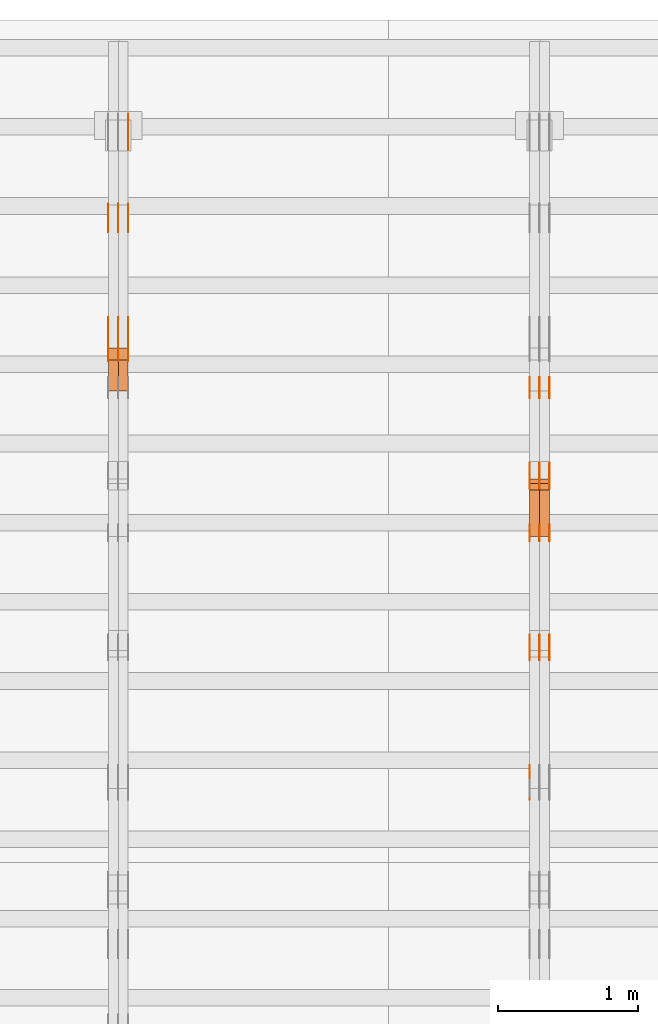
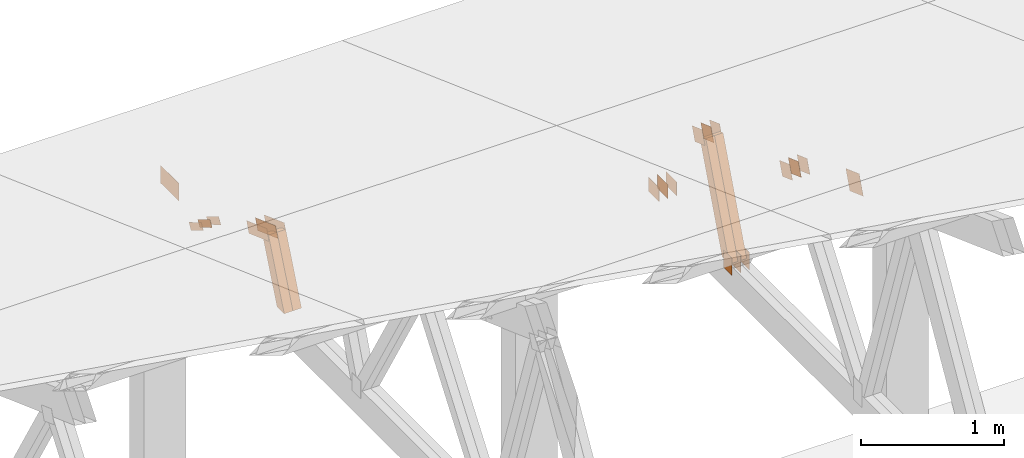
# One storey, part 117 of 189: 30 proxies.
"""IFC2X3 building model written with IfcOpenShell, lengths in millimetres."""

from ifc_helpers import new_model, entity, si_unit, converted_unit, derived_unit, direction, frame, frame_2d, origin, origin_2d_with_axis, place, context, subcontext, project, spatial, polyline, rectangle, outline, extrude, source, transform, mapped, material, type_object, type_shapes, element, save


model = new_model("IFC2X3")

# Units and contexts
model_context = context("Model", 3, precision=0.01, world=origin(), true_north=direction((6.12303176911189e-17, 1.0)))
body_context = subcontext(model_context, "Body", "Model", "MODEL_VIEW")
ifc_project = project(units=[si_unit("LENGTHUNIT", "METRE", prefix="MILLI"), si_unit("AREAUNIT", "SQUARE_METRE"), si_unit("VOLUMEUNIT", "CUBIC_METRE"), converted_unit("PLANEANGLEUNIT", "DEGREE", entity("IfcRatioMeasure", 0.0174532925199433), si_unit("PLANEANGLEUNIT", "RADIAN"), dimensions=[0, 0, 0, 0, 0, 0, 0]), si_unit("MASSUNIT", "GRAM", prefix="KILO"), derived_unit("MASSDENSITYUNIT", [(si_unit("MASSUNIT", "GRAM", prefix="KILO"), 1), (si_unit("LENGTHUNIT", "METRE"), -3)]), si_unit("TIMEUNIT", "SECOND"), si_unit("FREQUENCYUNIT", "HERTZ"), si_unit("THERMODYNAMICTEMPERATUREUNIT", "DEGREE_CELSIUS"), derived_unit("THERMALTRANSMITTANCEUNIT", [(si_unit("MASSUNIT", "GRAM", prefix="KILO"), 1), (si_unit("THERMODYNAMICTEMPERATUREUNIT", "KELVIN"), -1), (si_unit("TIMEUNIT", "SECOND"), -3)]), derived_unit("VOLUMETRICFLOWRATEUNIT", [(si_unit("LENGTHUNIT", "METRE"), 3), (si_unit("TIMEUNIT", "SECOND"), -1)]), si_unit("ELECTRICCURRENTUNIT", "AMPERE"), si_unit("ELECTRICVOLTAGEUNIT", "VOLT"), si_unit("POWERUNIT", "WATT"), si_unit("FORCEUNIT", "NEWTON"), si_unit("ILLUMINANCEUNIT", "LUX"), si_unit("LUMINOUSFLUXUNIT", "LUMEN"), si_unit("LUMINOUSINTENSITYUNIT", "CANDELA"), derived_unit("USERDEFINED", [(si_unit("MASSUNIT", "GRAM", prefix="KILO"), -1), (si_unit("LENGTHUNIT", "METRE"), -2), (si_unit("TIMEUNIT", "SECOND"), 3), (si_unit("LUMINOUSFLUXUNIT", "LUMEN"), 1)]), derived_unit("LINEARVELOCITYUNIT", [(si_unit("LENGTHUNIT", "METRE"), 1), (si_unit("TIMEUNIT", "SECOND"), -1)]), si_unit("PRESSUREUNIT", "PASCAL"), derived_unit("USERDEFINED", [(si_unit("LENGTHUNIT", "METRE"), -2), (si_unit("MASSUNIT", "GRAM", prefix="KILO"), 1), (si_unit("TIMEUNIT", "SECOND"), -2)])], contexts=[model_context])

# Site, building, storey
site_placement = place(None, origin())
site = spatial("IfcSite", under=ifc_project, at=site_placement, CompositionType="ELEMENT")
building_placement = place(site_placement, origin())
building = spatial("IfcBuilding", under=site, at=building_placement, CompositionType="ELEMENT")
storey_placement = place(building_placement, origin())
storey = spatial("IfcBuildingStorey", under=building, at=storey_placement, Name="Default", CompositionType="ELEMENT", Elevation=0.0)

# Proxies
ifc_material_1 = material(Name="IfcSurfaceStyle #73986")
building_element_proxy_type_1 = type_object("IfcBuildingElementProxyType", PredefinedType="NOTDEFINED", material=ifc_material_1)
shared_shape_1 = source(origin(), body_context, "Body", "SweptSolid", [
    extrude(outline(polyline([(-74.9999475298494, -60.0), (75.0000042257432, -60.0), (74.9999684051025, 60.0), (-75.0000251009963, 60.0), (-74.9999475298494, -60.0)])), frame((75.0000607644577, 60.0000865490217, 0.0), z_axis=(0.0, 0.0, 1.0), x_axis=(-1.0, 0.0, 0.0)), (0.0, 0.0, 1.0), 1.3),
])
type_shapes(building_element_proxy_type_1, [shared_shape_1])
proxy_1_placement = place(building_placement, frame((12301.3, 25732.0586805394, 1446.84420669249), z_axis=(-1.0, 0.0, 0.0), x_axis=(0.0, -0.939692620785908, 0.342020143325669)))
element("IfcBuildingElementProxy", 1, at=proxy_1_placement, inside=storey, type_object=building_element_proxy_type_1, material=ifc_material_1, context=body_context, shape_type="MappedRepresentation", body=[
    mapped(shared_shape_1, transform((0.0, 0.0, 0.0), scale=1.0)),
])
ifc_material_2 = material(Name="IfcSurfaceStyle #73929")
building_element_proxy_type_2 = type_object("IfcBuildingElementProxyType", PredefinedType="NOTDEFINED", material=ifc_material_2)
shared_shape_2 = source(origin(), body_context, "Body", "SweptSolid", [
    extrude(outline(polyline([(-74.9999475298494, -60.0), (75.0000042257432, -60.0), (74.9999684051025, 60.0), (-75.0000251009963, 60.0), (-74.9999475298494, -60.0)])), frame((75.0000607644577, 60.0000865490217, 0.0), z_axis=(0.0, 0.0, 1.0), x_axis=(-1.0, 0.0, 0.0)), (0.0, 0.0, 1.0), 1.29999999999999),
])
type_shapes(building_element_proxy_type_2, [shared_shape_2])
proxy_2_placement = place(building_placement, frame((12230.0, 25732.0586805394, 1446.84420669249), z_axis=(-1.0, 0.0, 0.0), x_axis=(0.0, -0.939692620785908, 0.342020143325669)))
element("IfcBuildingElementProxy", 2, at=proxy_2_placement, inside=storey, type_object=building_element_proxy_type_2, material=ifc_material_2, context=body_context, shape_type="MappedRepresentation", body=[
    mapped(shared_shape_2, transform((0.0, 0.0, 0.0), scale=1.0)),
])
ifc_material_3 = material(Name="IfcSurfaceStyle #73872")
building_element_proxy_type_3 = type_object("IfcBuildingElementProxyType", PredefinedType="NOTDEFINED", material=ifc_material_3)
shared_shape_3 = source(origin(), body_context, "Body", "SweptSolid", [
    extrude(outline(polyline([(-74.9999475298494, -60.0), (75.0000042257432, -60.0), (74.9999684051025, 60.0), (-75.0000251009963, 60.0), (-74.9999475298494, -60.0)])), frame((75.0000607644577, 60.0000865490217, 0.0), z_axis=(0.0, 0.0, 1.0), x_axis=(-1.0, 0.0, 0.0)), (0.0, 0.0, 1.0), 1.29999999999999),
])
type_shapes(building_element_proxy_type_3, [shared_shape_3])
proxy_3_placement = place(building_placement, frame((12231.3, 25732.0586805394, 1446.84420669249), z_axis=(-1.0, 0.0, 0.0), x_axis=(0.0, -0.939692620785908, 0.342020143325669)))
element("IfcBuildingElementProxy", 3, at=proxy_3_placement, inside=storey, type_object=building_element_proxy_type_3, material=ifc_material_3, context=body_context, shape_type="MappedRepresentation", body=[
    mapped(shared_shape_3, transform((0.0, 0.0, 0.0), scale=1.0)),
])
ifc_material_4 = material(Name="IfcSurfaceStyle #73815")
building_element_proxy_type_4 = type_object("IfcBuildingElementProxyType", PredefinedType="NOTDEFINED", material=ifc_material_4)
shared_shape_4 = source(origin(), body_context, "Body", "SweptSolid", [
    extrude(outline(polyline([(-74.9999475298494, -60.0), (75.0000042257432, -60.0), (74.9999684051025, 60.0), (-75.0000251009963, 60.0), (-74.9999475298494, -60.0)])), frame((75.0000607644577, 60.0000865490217, 0.0), z_axis=(0.0, 0.0, 1.0), x_axis=(-1.0, 0.0, 0.0)), (0.0, 0.0, 1.0), 1.29999999999999),
])
type_shapes(building_element_proxy_type_4, [shared_shape_4])
proxy_4_placement = place(building_placement, frame((12160.0, 25732.0586805394, 1446.84420669249), z_axis=(-1.0, 0.0, 0.0), x_axis=(0.0, -0.939692620785908, 0.342020143325669)))
element("IfcBuildingElementProxy", 4, at=proxy_4_placement, inside=storey, type_object=building_element_proxy_type_4, material=ifc_material_4, context=body_context, shape_type="MappedRepresentation", body=[
    mapped(shared_shape_4, transform((0.0, 0.0, 0.0), scale=1.0)),
])
ifc_material_5 = material(Name="IfcSurfaceStyle #73758")
building_element_proxy_type_5 = type_object("IfcBuildingElementProxyType", PredefinedType="NOTDEFINED", material=ifc_material_5)
shared_shape_5 = source(origin(), body_context, "Body", "SweptSolid", [
    extrude(rectangle(XDim=150.0, YDim=120.0, at=frame_2d((-7.105427357601e-15, 0.0), x_axis=(1.0, 0.0))), frame((75.0, 60.0, 0.0), z_axis=(0.0, 0.0, 1.0), x_axis=(-1.0, 0.0, 0.0)), (0.0, 0.0, 1.0), 1.3),
])
type_shapes(building_element_proxy_type_5, [shared_shape_5])
proxy_5_placement = place(building_placement, frame((12301.3, 26439.0083007813, 170.0), z_axis=(-1.0, 0.0, 0.0), x_axis=(0.0, 0.0, 1.0)))
element("IfcBuildingElementProxy", 5, at=proxy_5_placement, inside=storey, type_object=building_element_proxy_type_5, material=ifc_material_5, context=body_context, shape_type="MappedRepresentation", body=[
    mapped(shared_shape_5, transform((0.0, 0.0, 0.0), scale=1.0)),
])
ifc_material_6 = material(Name="IfcSurfaceStyle #73701")
building_element_proxy_type_6 = type_object("IfcBuildingElementProxyType", PredefinedType="NOTDEFINED", material=ifc_material_6)
shared_shape_6 = source(origin(), body_context, "Body", "SweptSolid", [
    extrude(rectangle(XDim=150.0, YDim=120.0, at=frame_2d((-7.105427357601e-15, 0.0), x_axis=(1.0, 0.0))), frame((75.0, 60.0, 0.0), z_axis=(0.0, 0.0, 1.0), x_axis=(-1.0, 0.0, 0.0)), (0.0, 0.0, 1.0), 1.29999999999999),
])
type_shapes(building_element_proxy_type_6, [shared_shape_6])
proxy_6_placement = place(building_placement, frame((12230.0, 26439.0083007813, 170.0), z_axis=(-1.0, 0.0, 0.0), x_axis=(0.0, 0.0, 1.0)))
element("IfcBuildingElementProxy", 6, at=proxy_6_placement, inside=storey, type_object=building_element_proxy_type_6, material=ifc_material_6, context=body_context, shape_type="MappedRepresentation", body=[
    mapped(shared_shape_6, transform((0.0, 0.0, 0.0), scale=1.0)),
])
ifc_material_7 = material(Name="IfcSurfaceStyle #73644")
building_element_proxy_type_7 = type_object("IfcBuildingElementProxyType", PredefinedType="NOTDEFINED", material=ifc_material_7)
shared_shape_7 = source(origin(), body_context, "Body", "SweptSolid", [
    extrude(rectangle(XDim=150.0, YDim=120.0, at=frame_2d((-7.105427357601e-15, 0.0), x_axis=(1.0, 0.0))), frame((75.0, 60.0, 0.0), z_axis=(0.0, 0.0, 1.0), x_axis=(-1.0, 0.0, 0.0)), (0.0, 0.0, 1.0), 1.29999999999999),
])
type_shapes(building_element_proxy_type_7, [shared_shape_7])
proxy_7_placement = place(building_placement, frame((12231.3, 26439.0083007813, 170.0), z_axis=(-1.0, 0.0, 0.0), x_axis=(0.0, 0.0, 1.0)))
element("IfcBuildingElementProxy", 7, at=proxy_7_placement, inside=storey, type_object=building_element_proxy_type_7, material=ifc_material_7, context=body_context, shape_type="MappedRepresentation", body=[
    mapped(shared_shape_7, transform((0.0, 0.0, 0.0), scale=1.0)),
])
ifc_material_8 = material(Name="IfcSurfaceStyle #73587")
building_element_proxy_type_8 = type_object("IfcBuildingElementProxyType", PredefinedType="NOTDEFINED", material=ifc_material_8)
shared_shape_8 = source(origin(), body_context, "Body", "SweptSolid", [
    extrude(rectangle(XDim=150.0, YDim=120.0, at=frame_2d((-7.105427357601e-15, 0.0), x_axis=(1.0, 0.0))), frame((75.0, 60.0, 0.0), z_axis=(0.0, 0.0, 1.0), x_axis=(-1.0, 0.0, 0.0)), (0.0, 0.0, 1.0), 1.29999999999999),
])
type_shapes(building_element_proxy_type_8, [shared_shape_8])
proxy_8_placement = place(building_placement, frame((12160.0, 26439.0083007813, 170.0), z_axis=(-1.0, 0.0, 0.0), x_axis=(0.0, 0.0, 1.0)))
element("IfcBuildingElementProxy", 8, at=proxy_8_placement, inside=storey, type_object=building_element_proxy_type_8, material=ifc_material_8, context=body_context, shape_type="MappedRepresentation", body=[
    mapped(shared_shape_8, transform((0.0, 0.0, 0.0), scale=1.0)),
])
ifc_material_9 = material(Name="IfcSurfaceStyle #73074")
building_element_proxy_type_9 = type_object("IfcBuildingElementProxyType", PredefinedType="NOTDEFINED", material=ifc_material_9)
shared_shape_9 = source(origin(), body_context, "Body", "SweptSolid", [
    extrude(outline(polyline([(-74.9999684051023, -60.0), (75.0000251009964, -60.0), (74.9999475298495, 60.0), (-75.0000042257435, 60.0), (-74.9999684051023, -60.0)])), frame((75.0000251009964, 60.0000006265238, 0.0), z_axis=(0.0, 0.0, 1.0), x_axis=(-1.0, 0.0, 0.0)), (0.0, 0.0, 1.0), 1.3),
])
type_shapes(building_element_proxy_type_9, [shared_shape_9])
proxy_9_placement = place(building_placement, frame((12301.3, 26956.490053282, 1001.18769055967), z_axis=(-1.0, 0.0, 0.0), x_axis=(0.0, -0.939692620785908, 0.342020143325669)))
element("IfcBuildingElementProxy", 9, at=proxy_9_placement, inside=storey, type_object=building_element_proxy_type_9, material=ifc_material_9, context=body_context, shape_type="MappedRepresentation", body=[
    mapped(shared_shape_9, transform((0.0, 0.0, 0.0), scale=1.0)),
])
ifc_material_10 = material(Name="IfcSurfaceStyle #73017")
building_element_proxy_type_10 = type_object("IfcBuildingElementProxyType", PredefinedType="NOTDEFINED", material=ifc_material_10)
shared_shape_10 = source(origin(), body_context, "Body", "SweptSolid", [
    extrude(outline(polyline([(-74.9999684051023, -60.0), (75.0000251009964, -60.0), (74.9999475298495, 60.0), (-75.0000042257435, 60.0), (-74.9999684051023, -60.0)])), frame((75.0000251009964, 60.0000006265238, 0.0), z_axis=(0.0, 0.0, 1.0), x_axis=(-1.0, 0.0, 0.0)), (0.0, 0.0, 1.0), 1.29999999999999),
])
type_shapes(building_element_proxy_type_10, [shared_shape_10])
proxy_10_placement = place(building_placement, frame((12230.0, 26956.490053282, 1001.18769055967), z_axis=(-1.0, 0.0, 0.0), x_axis=(0.0, -0.939692620785908, 0.342020143325669)))
element("IfcBuildingElementProxy", 10, at=proxy_10_placement, inside=storey, type_object=building_element_proxy_type_10, material=ifc_material_10, context=body_context, shape_type="MappedRepresentation", body=[
    mapped(shared_shape_10, transform((0.0, 0.0, 0.0), scale=1.0)),
])
ifc_material_11 = material(Name="IfcSurfaceStyle #72960")
building_element_proxy_type_11 = type_object("IfcBuildingElementProxyType", PredefinedType="NOTDEFINED", material=ifc_material_11)
shared_shape_11 = source(origin(), body_context, "Body", "SweptSolid", [
    extrude(outline(polyline([(-74.9999684051023, -60.0), (75.0000251009964, -60.0), (74.9999475298495, 60.0), (-75.0000042257435, 60.0), (-74.9999684051023, -60.0)])), frame((75.0000251009964, 60.0000006265238, 0.0), z_axis=(0.0, 0.0, 1.0), x_axis=(-1.0, 0.0, 0.0)), (0.0, 0.0, 1.0), 1.29999999999999),
])
type_shapes(building_element_proxy_type_11, [shared_shape_11])
proxy_11_placement = place(building_placement, frame((12231.3, 26956.490053282, 1001.18769055967), z_axis=(-1.0, 0.0, 0.0), x_axis=(0.0, -0.939692620785908, 0.342020143325669)))
element("IfcBuildingElementProxy", 11, at=proxy_11_placement, inside=storey, type_object=building_element_proxy_type_11, material=ifc_material_11, context=body_context, shape_type="MappedRepresentation", body=[
    mapped(shared_shape_11, transform((0.0, 0.0, 0.0), scale=1.0)),
])
ifc_material_12 = material(Name="IfcSurfaceStyle #72903")
building_element_proxy_type_12 = type_object("IfcBuildingElementProxyType", PredefinedType="NOTDEFINED", material=ifc_material_12)
shared_shape_12 = source(origin(), body_context, "Body", "SweptSolid", [
    extrude(outline(polyline([(-74.9999684051023, -60.0), (75.0000251009964, -60.0), (74.9999475298495, 60.0), (-75.0000042257435, 60.0), (-74.9999684051023, -60.0)])), frame((75.0000251009964, 60.0000006265238, 0.0), z_axis=(0.0, 0.0, 1.0), x_axis=(-1.0, 0.0, 0.0)), (0.0, 0.0, 1.0), 1.29999999999999),
])
type_shapes(building_element_proxy_type_12, [shared_shape_12])
proxy_12_placement = place(building_placement, frame((12160.0, 26956.490053282, 1001.18769055967), z_axis=(-1.0, 0.0, 0.0), x_axis=(0.0, -0.939692620785908, 0.342020143325669)))
element("IfcBuildingElementProxy", 12, at=proxy_12_placement, inside=storey, type_object=building_element_proxy_type_12, material=ifc_material_12, context=body_context, shape_type="MappedRepresentation", body=[
    mapped(shared_shape_12, transform((0.0, 0.0, 0.0), scale=1.0)),
])
ifc_material_13 = material(Name="IfcSurfaceStyle #72846")
building_element_proxy_type_13 = type_object("IfcBuildingElementProxyType", PredefinedType="NOTDEFINED", material=ifc_material_13)
shared_shape_13 = source(origin(), body_context, "Body", "SweptSolid", [
    extrude(rectangle(XDim=150.0, YDim=120.0, at=origin_2d_with_axis()), frame((75.0, 60.0, 0.0), z_axis=(0.0, 0.0, 1.0), x_axis=(-1.0, 0.0, 0.0)), (0.0, 0.0, 1.0), 1.3),
])
type_shapes(building_element_proxy_type_13, [shared_shape_13])
proxy_13_placement = place(building_placement, frame((12301.3, 27607.3129882813, 185.0), z_axis=(-1.0, 0.0, 0.0), x_axis=(0.0, -1.0, 0.0)))
element("IfcBuildingElementProxy", 13, at=proxy_13_placement, inside=storey, type_object=building_element_proxy_type_13, material=ifc_material_13, context=body_context, shape_type="MappedRepresentation", body=[
    mapped(shared_shape_13, transform((0.0, 0.0, 0.0), scale=1.0)),
])
ifc_material_14 = material(Name="IfcSurfaceStyle #72789")
building_element_proxy_type_14 = type_object("IfcBuildingElementProxyType", PredefinedType="NOTDEFINED", material=ifc_material_14)
shared_shape_14 = source(origin(), body_context, "Body", "SweptSolid", [
    extrude(rectangle(XDim=150.0, YDim=120.0, at=origin_2d_with_axis()), frame((75.0, 60.0, 0.0), z_axis=(0.0, 0.0, 1.0), x_axis=(-1.0, 0.0, 0.0)), (0.0, 0.0, 1.0), 1.29999999999999),
])
type_shapes(building_element_proxy_type_14, [shared_shape_14])
proxy_14_placement = place(building_placement, frame((12230.0, 27607.3129882813, 185.0), z_axis=(-1.0, 0.0, 0.0), x_axis=(0.0, -1.0, 0.0)))
element("IfcBuildingElementProxy", 14, at=proxy_14_placement, inside=storey, type_object=building_element_proxy_type_14, material=ifc_material_14, context=body_context, shape_type="MappedRepresentation", body=[
    mapped(shared_shape_14, transform((0.0, 0.0, 0.0), scale=1.0)),
])
ifc_material_15 = material(Name="IfcSurfaceStyle #72732")
building_element_proxy_type_15 = type_object("IfcBuildingElementProxyType", PredefinedType="NOTDEFINED", material=ifc_material_15)
shared_shape_15 = source(origin(), body_context, "Body", "SweptSolid", [
    extrude(rectangle(XDim=150.0, YDim=120.0, at=origin_2d_with_axis()), frame((75.0, 60.0, 0.0), z_axis=(0.0, 0.0, 1.0), x_axis=(-1.0, 0.0, 0.0)), (0.0, 0.0, 1.0), 1.29999999999999),
])
type_shapes(building_element_proxy_type_15, [shared_shape_15])
proxy_15_placement = place(building_placement, frame((12231.3, 27607.3129882813, 185.0), z_axis=(-1.0, 0.0, 0.0), x_axis=(0.0, -1.0, 0.0)))
element("IfcBuildingElementProxy", 15, at=proxy_15_placement, inside=storey, type_object=building_element_proxy_type_15, material=ifc_material_15, context=body_context, shape_type="MappedRepresentation", body=[
    mapped(shared_shape_15, transform((0.0, 0.0, 0.0), scale=1.0)),
])
ifc_material_16 = material(Name="IfcSurfaceStyle #72675")
building_element_proxy_type_16 = type_object("IfcBuildingElementProxyType", PredefinedType="NOTDEFINED", material=ifc_material_16)
shared_shape_16 = source(origin(), body_context, "Body", "SweptSolid", [
    extrude(rectangle(XDim=150.0, YDim=120.0, at=origin_2d_with_axis()), frame((75.0, 60.0, 0.0), z_axis=(0.0, 0.0, 1.0), x_axis=(-1.0, 0.0, 0.0)), (0.0, 0.0, 1.0), 1.29999999999999),
])
type_shapes(building_element_proxy_type_16, [shared_shape_16])
proxy_16_placement = place(building_placement, frame((12160.0, 27607.3129882813, 185.0), z_axis=(-1.0, 0.0, 0.0), x_axis=(0.0, -1.0, 0.0)))
element("IfcBuildingElementProxy", 16, at=proxy_16_placement, inside=storey, type_object=building_element_proxy_type_16, material=ifc_material_16, context=body_context, shape_type="MappedRepresentation", body=[
    mapped(shared_shape_16, transform((0.0, 0.0, 0.0), scale=1.0)),
])
ifc_material_17 = material(Name="IfcSurfaceStyle #68691")
building_element_proxy_type_17 = type_object("IfcBuildingElementProxyType", PredefinedType="NOTDEFINED", material=ifc_material_17)
shared_shape_17 = source(origin(), body_context, "Body", "SweptSolid", [
    extrude(outline(polyline([(-99.9999065788418, -84.0000755647729), (99.9999734279406, -84.0000755647729), (99.9999483293475, 84.000075564773), (-100.000015178446, 84.000075564773), (-99.9999065788418, -84.0000755647729)])), frame((100.000157783747, 84.0001144608011, 0.0), z_axis=(0.0, 0.0, 1.0), x_axis=(-1.0, 0.0, 0.0)), (0.0, 0.0, 1.0), 1.29999999999999),
])
type_shapes(building_element_proxy_type_17, [shared_shape_17])
proxy_17_placement = place(building_placement, frame((12160.0, 24788.4767593228, 1895.10136879206), z_axis=(-1.0, 0.0, 0.0), x_axis=(0.0, -0.939692620785908, 0.342020143325669)))
element("IfcBuildingElementProxy", 17, at=proxy_17_placement, inside=storey, type_object=building_element_proxy_type_17, material=ifc_material_17, context=body_context, shape_type="MappedRepresentation", body=[
    mapped(shared_shape_17, transform((0.0, 0.0, 0.0), scale=1.0)),
])
ifc_material_18 = material(Name="IfcSurfaceStyle #65598")
building_element_proxy_type_18 = type_object("IfcBuildingElementProxyType", Name="T1-W14 65596", PredefinedType="NOTDEFINED", material=ifc_material_18)
shared_shape_18 = source(origin(), body_context, "Body", "SweptSolid", [
    extrude(outline(polyline([(-561.981237417233, -47.499947472121), (373.092610496013, -47.499947472121), (373.679602940405, -4.61719047935016e-05), (341.277449358876, 47.4999705580734), (-526.068425378061, 47.4999705580734), (-561.981237417233, -47.499947472121)])), frame((373.679632439416, 47.500120814091, 0.0), z_axis=(0.0, 0.0, 1.0), x_axis=(-1.0, 0.0, 0.0)), (0.0, 0.0, 1.0), 69.9999999999999),
])
type_shapes(building_element_proxy_type_18, [shared_shape_18])
proxy_18_placement = place(building_placement, frame((12300.0, 26895.4809555667, 1086.61918844835), z_axis=(-1.0, 0.0, 0.0), x_axis=(0.0, -0.353606472447933, -0.935394281916951)))
element("IfcBuildingElementProxy", 18, at=proxy_18_placement, inside=storey, type_object=building_element_proxy_type_18, material=ifc_material_18, Name="T1-W14", context=body_context, shape_type="MappedRepresentation", body=[
    mapped(shared_shape_18, transform((0.0, 0.0, 0.0), scale=1.0)),
])
ifc_material_19 = material(Name="IfcSurfaceStyle #65532")
building_element_proxy_type_19 = type_object("IfcBuildingElementProxyType", Name="T1-W14 65530", PredefinedType="NOTDEFINED", material=ifc_material_19)
shared_shape_19 = source(origin(), body_context, "Body", "SweptSolid", [
    extrude(outline(polyline([(-561.981237417233, -47.499947472121), (373.092610496013, -47.499947472121), (373.679602940405, -4.61719047935016e-05), (341.277449358876, 47.4999705580734), (-526.068425378061, 47.4999705580734), (-561.981237417233, -47.499947472121)])), frame((373.679632439416, 47.500120814091, 0.0), z_axis=(0.0, 0.0, 1.0), x_axis=(-1.0, 0.0, 0.0)), (0.0, 0.0, 1.0), 69.9999999999999),
])
type_shapes(building_element_proxy_type_19, [shared_shape_19])
proxy_19_placement = place(building_placement, frame((12230.0, 26895.4809555667, 1086.61918844835), z_axis=(-1.0, 0.0, 0.0), x_axis=(0.0, -0.353606472447933, -0.935394281916951)))
element("IfcBuildingElementProxy", 19, at=proxy_19_placement, inside=storey, type_object=building_element_proxy_type_19, material=ifc_material_19, Name="T1-W14", context=body_context, shape_type="MappedRepresentation", body=[
    mapped(shared_shape_19, transform((0.0, 0.0, 0.0), scale=1.0)),
])
ifc_material_20 = material(Name="IfcSurfaceStyle #56372")
building_element_proxy_type_20 = type_object("IfcBuildingElementProxyType", PredefinedType="NOTDEFINED", material=ifc_material_20)
shared_shape_20 = source(origin(), body_context, "Body", "SweptSolid", [
    extrude(outline(polyline([(-150.000004175486, -48.0000091256405), (150.000055794777, -48.0000091256405), (149.99999373786, 48.0000091256405), (-150.000045357151, 48.0000091256405), (-150.000004175486, -48.0000091256405)])), frame((150.000055794777, 48.0000091256405, 0.0), z_axis=(0.0, 0.0, 1.0), x_axis=(-1.0, 0.0, 0.0)), (0.0, 0.0, 1.0), 1.29999999999999),
])
type_shapes(building_element_proxy_type_20, [shared_shape_20])
proxy_20_placement = place(building_placement, frame((9301.3, 28002.7008500375, 633.16821439849), z_axis=(-1.0, 0.0, 0.0), x_axis=(0.0, -0.939692620785908, 0.342020143325669)))
element("IfcBuildingElementProxy", 20, at=proxy_20_placement, inside=storey, type_object=building_element_proxy_type_20, material=ifc_material_20, context=body_context, shape_type="MappedRepresentation", body=[
    mapped(shared_shape_20, transform((0.0, 0.0, 0.0), scale=1.0)),
])
ifc_material_21 = material(Name="IfcSurfaceStyle #56315")
building_element_proxy_type_21 = type_object("IfcBuildingElementProxyType", PredefinedType="NOTDEFINED", material=ifc_material_21)
shared_shape_21 = source(origin(), body_context, "Body", "SweptSolid", [
    extrude(outline(polyline([(-150.000004175486, -48.0000091256405), (150.000055794777, -48.0000091256405), (149.99999373786, 48.0000091256405), (-150.000045357151, 48.0000091256405), (-150.000004175486, -48.0000091256405)])), frame((150.000055794777, 48.0000091256405, 0.0), z_axis=(0.0, 0.0, 1.0), x_axis=(-1.0, 0.0, 0.0)), (0.0, 0.0, 1.0), 1.29999999999998),
])
type_shapes(building_element_proxy_type_21, [shared_shape_21])
proxy_21_placement = place(building_placement, frame((9230.0, 28002.7008500375, 633.16821439849), z_axis=(-1.0, 0.0, 0.0), x_axis=(0.0, -0.939692620785908, 0.342020143325669)))
element("IfcBuildingElementProxy", 21, at=proxy_21_placement, inside=storey, type_object=building_element_proxy_type_21, material=ifc_material_21, context=body_context, shape_type="MappedRepresentation", body=[
    mapped(shared_shape_21, transform((0.0, 0.0, 0.0), scale=1.0)),
])
ifc_material_22 = material(Name="IfcSurfaceStyle #56258")
building_element_proxy_type_22 = type_object("IfcBuildingElementProxyType", PredefinedType="NOTDEFINED", material=ifc_material_22)
shared_shape_22 = source(origin(), body_context, "Body", "SweptSolid", [
    extrude(outline(polyline([(-150.000004175486, -48.0000091256405), (150.000055794777, -48.0000091256405), (149.99999373786, 48.0000091256405), (-150.000045357151, 48.0000091256405), (-150.000004175486, -48.0000091256405)])), frame((150.000055794777, 48.0000091256405, 0.0), z_axis=(0.0, 0.0, 1.0), x_axis=(-1.0, 0.0, 0.0)), (0.0, 0.0, 1.0), 1.29999999999998),
])
type_shapes(building_element_proxy_type_22, [shared_shape_22])
proxy_22_placement = place(building_placement, frame((9231.3, 28002.7008500375, 633.16821439849), z_axis=(-1.0, 0.0, 0.0), x_axis=(0.0, -0.939692620785908, 0.342020143325669)))
element("IfcBuildingElementProxy", 22, at=proxy_22_placement, inside=storey, type_object=building_element_proxy_type_22, material=ifc_material_22, context=body_context, shape_type="MappedRepresentation", body=[
    mapped(shared_shape_22, transform((0.0, 0.0, 0.0), scale=1.0)),
])
ifc_material_23 = material(Name="IfcSurfaceStyle #56201")
building_element_proxy_type_23 = type_object("IfcBuildingElementProxyType", PredefinedType="NOTDEFINED", material=ifc_material_23)
shared_shape_23 = source(origin(), body_context, "Body", "SweptSolid", [
    extrude(outline(polyline([(-150.000004175486, -48.0000091256405), (150.000055794777, -48.0000091256405), (149.99999373786, 48.0000091256405), (-150.000045357151, 48.0000091256405), (-150.000004175486, -48.0000091256405)])), frame((150.000055794777, 48.0000091256405, 0.0), z_axis=(0.0, 0.0, 1.0), x_axis=(-1.0, 0.0, 0.0)), (0.0, 0.0, 1.0), 1.29999999999998),
])
type_shapes(building_element_proxy_type_23, [shared_shape_23])
proxy_23_placement = place(building_placement, frame((9160.0, 28002.7008500375, 633.16821439849), z_axis=(-1.0, 0.0, 0.0), x_axis=(0.0, -0.939692620785908, 0.342020143325669)))
element("IfcBuildingElementProxy", 23, at=proxy_23_placement, inside=storey, type_object=building_element_proxy_type_23, material=ifc_material_23, context=body_context, shape_type="MappedRepresentation", body=[
    mapped(shared_shape_23, transform((0.0, 0.0, 0.0), scale=1.0)),
])
ifc_material_24 = material(Name="IfcSurfaceStyle #56144")
building_element_proxy_type_24 = type_object("IfcBuildingElementProxyType", PredefinedType="NOTDEFINED", material=ifc_material_24)
shared_shape_24 = source(origin(), body_context, "Body", "SweptSolid", [
    extrude(outline(polyline([(-100.000014621824, -30.0000173081658), (100.000025679578, -30.0000173081658), (100.000010707989, 30.0000173081658), (-100.000021765743, 30.0000173081658), (-100.000014621824, -30.0000173081658)])), frame((100.000025679578, 30.0000173081658, 0.0), z_axis=(0.0, 0.0, 1.0), x_axis=(-1.0, 0.0, 0.0)), (0.0, 0.0, 1.0), 1.3),
])
type_shapes(building_element_proxy_type_24, [shared_shape_24])
proxy_24_placement = place(building_placement, frame((9301.3, 28812.2744732883, 167.948789809131), z_axis=(-1.0, 0.0, 0.0), x_axis=(0.0, -0.858392121304013, 0.51299411895576)))
element("IfcBuildingElementProxy", 24, at=proxy_24_placement, inside=storey, type_object=building_element_proxy_type_24, material=ifc_material_24, context=body_context, shape_type="MappedRepresentation", body=[
    mapped(shared_shape_24, transform((0.0, 0.0, 0.0), scale=1.0)),
])
ifc_material_25 = material(Name="IfcSurfaceStyle #56087")
building_element_proxy_type_25 = type_object("IfcBuildingElementProxyType", PredefinedType="NOTDEFINED", material=ifc_material_25)
shared_shape_25 = source(origin(), body_context, "Body", "SweptSolid", [
    extrude(outline(polyline([(-100.000014621824, -30.0000173081658), (100.000025679578, -30.0000173081658), (100.000010707989, 30.0000173081658), (-100.000021765743, 30.0000173081658), (-100.000014621824, -30.0000173081658)])), frame((100.000025679578, 30.0000173081658, 0.0), z_axis=(0.0, 0.0, 1.0), x_axis=(-1.0, 0.0, 0.0)), (0.0, 0.0, 1.0), 1.29999999999998),
])
type_shapes(building_element_proxy_type_25, [shared_shape_25])
proxy_25_placement = place(building_placement, frame((9230.0, 28812.2744732883, 167.948789809131), z_axis=(-1.0, 0.0, 0.0), x_axis=(0.0, -0.858392121304013, 0.51299411895576)))
element("IfcBuildingElementProxy", 25, at=proxy_25_placement, inside=storey, type_object=building_element_proxy_type_25, material=ifc_material_25, context=body_context, shape_type="MappedRepresentation", body=[
    mapped(shared_shape_25, transform((0.0, 0.0, 0.0), scale=1.0)),
])
ifc_material_26 = material(Name="IfcSurfaceStyle #56030")
building_element_proxy_type_26 = type_object("IfcBuildingElementProxyType", PredefinedType="NOTDEFINED", material=ifc_material_26)
shared_shape_26 = source(origin(), body_context, "Body", "SweptSolid", [
    extrude(outline(polyline([(-100.000014621824, -30.0000173081658), (100.000025679578, -30.0000173081658), (100.000010707989, 30.0000173081658), (-100.000021765743, 30.0000173081658), (-100.000014621824, -30.0000173081658)])), frame((100.000025679578, 30.0000173081658, 0.0), z_axis=(0.0, 0.0, 1.0), x_axis=(-1.0, 0.0, 0.0)), (0.0, 0.0, 1.0), 1.29999999999998),
])
type_shapes(building_element_proxy_type_26, [shared_shape_26])
proxy_26_placement = place(building_placement, frame((9231.3, 28812.2744732883, 167.948789809131), z_axis=(-1.0, 0.0, 0.0), x_axis=(0.0, -0.858392121304013, 0.51299411895576)))
element("IfcBuildingElementProxy", 26, at=proxy_26_placement, inside=storey, type_object=building_element_proxy_type_26, material=ifc_material_26, context=body_context, shape_type="MappedRepresentation", body=[
    mapped(shared_shape_26, transform((0.0, 0.0, 0.0), scale=1.0)),
])
ifc_material_27 = material(Name="IfcSurfaceStyle #55973")
building_element_proxy_type_27 = type_object("IfcBuildingElementProxyType", PredefinedType="NOTDEFINED", material=ifc_material_27)
shared_shape_27 = source(origin(), body_context, "Body", "SweptSolid", [
    extrude(outline(polyline([(-100.000014621824, -30.0000173081658), (100.000025679578, -30.0000173081658), (100.000010707989, 30.0000173081658), (-100.000021765743, 30.0000173081658), (-100.000014621824, -30.0000173081658)])), frame((100.000025679578, 30.0000173081658, 0.0), z_axis=(0.0, 0.0, 1.0), x_axis=(-1.0, 0.0, 0.0)), (0.0, 0.0, 1.0), 1.29999999999999),
])
type_shapes(building_element_proxy_type_27, [shared_shape_27])
proxy_27_placement = place(building_placement, frame((9160.0, 28812.2744732883, 167.948789809131), z_axis=(-1.0, 0.0, 0.0), x_axis=(0.0, -0.858392121304013, 0.51299411895576)))
element("IfcBuildingElementProxy", 27, at=proxy_27_placement, inside=storey, type_object=building_element_proxy_type_27, material=ifc_material_27, context=body_context, shape_type="MappedRepresentation", body=[
    mapped(shared_shape_27, transform((0.0, 0.0, 0.0), scale=1.0)),
])
ifc_material_28 = material(Name="IfcSurfaceStyle #55688")
building_element_proxy_type_28 = type_object("IfcBuildingElementProxyType", PredefinedType="NOTDEFINED", material=ifc_material_28)
shared_shape_28 = source(origin(), body_context, "Body", "SweptSolid", [
    extrude(rectangle(XDim=258.000001907349, YDim=151.999992370605, at=origin_2d_with_axis()), frame((129.000001782157, 75.9999961853027, 0.0), z_axis=(0.0, 0.0, 1.0), x_axis=(-1.0, 0.0, 0.0)), (0.0, 0.0, 1.0), 0.999999999999984),
])
type_shapes(building_element_proxy_type_28, [shared_shape_28])
proxy_28_placement = place(building_placement, frame((9301.0, 29483.7634609878, 116.138221740723), z_axis=(-1.0, 0.0, 0.0), x_axis=(0.0, -1.0, 0.0)))
element("IfcBuildingElementProxy", 28, at=proxy_28_placement, inside=storey, type_object=building_element_proxy_type_28, material=ifc_material_28, Name="GNT100S 152x258", context=body_context, shape_type="MappedRepresentation", body=[
    mapped(shared_shape_28, transform((0.0, 0.0, 0.0), scale=1.0)),
])
ifc_material_29 = material(Name="IfcSurfaceStyle #49280")
building_element_proxy_type_29 = type_object("IfcBuildingElementProxyType", Name="T1-W15 49278", PredefinedType="NOTDEFINED", material=ifc_material_29)
shared_shape_29 = source(origin(), body_context, "Body", "SweptSolid", [
    extrude(outline(polyline([(-356.314733086722, -47.5000181042257), (225.500284389883, -47.5000181042257), (227.502094104438, -2.00397075419828e-05), (220.445344962296, 47.5000281240794), (-317.132990369895, 47.5000281240795), (-356.314733086722, -47.5000181042257)])), frame((227.502118521083, 47.5000281240794, 0.0), z_axis=(0.0, 0.0, 1.0), x_axis=(-1.0, 0.0, 0.0)), (0.0, 0.0, 1.0), 70.0),
])
type_shapes(building_element_proxy_type_29, [shared_shape_29])
proxy_29_placement = place(building_placement, frame((9300.0, 27820.3452927615, 748.492381554869), z_axis=(-1.0, 0.0, 0.0), x_axis=(0.0, -0.38128326679549, -0.9244582578255)))
element("IfcBuildingElementProxy", 29, at=proxy_29_placement, inside=storey, type_object=building_element_proxy_type_29, material=ifc_material_29, Name="T1-W15", context=body_context, shape_type="MappedRepresentation", body=[
    mapped(shared_shape_29, transform((0.0, 0.0, 0.0), scale=1.0)),
])
ifc_material_30 = material(Name="IfcSurfaceStyle #49214")
building_element_proxy_type_30 = type_object("IfcBuildingElementProxyType", Name="T1-W15 49212", PredefinedType="NOTDEFINED", material=ifc_material_30)
shared_shape_30 = source(origin(), body_context, "Body", "SweptSolid", [
    extrude(outline(polyline([(-356.314733086722, -47.5000181042257), (225.500284389883, -47.5000181042257), (227.502094104438, -2.00397075419828e-05), (220.445344962296, 47.5000281240794), (-317.132990369895, 47.5000281240795), (-356.314733086722, -47.5000181042257)])), frame((227.502118521083, 47.5000281240794, 0.0), z_axis=(0.0, 0.0, 1.0), x_axis=(-1.0, 0.0, 0.0)), (0.0, 0.0, 1.0), 70.0),
])
type_shapes(building_element_proxy_type_30, [shared_shape_30])
proxy_30_placement = place(building_placement, frame((9230.0, 27820.3452927615, 748.492381554869), z_axis=(-1.0, 0.0, 0.0), x_axis=(0.0, -0.38128326679549, -0.9244582578255)))
element("IfcBuildingElementProxy", 30, at=proxy_30_placement, inside=storey, type_object=building_element_proxy_type_30, material=ifc_material_30, Name="T1-W15", context=body_context, shape_type="MappedRepresentation", body=[
    mapped(shared_shape_30, transform((0.0, 0.0, 0.0), scale=1.0)),
])

save(model, "model.ifc")
